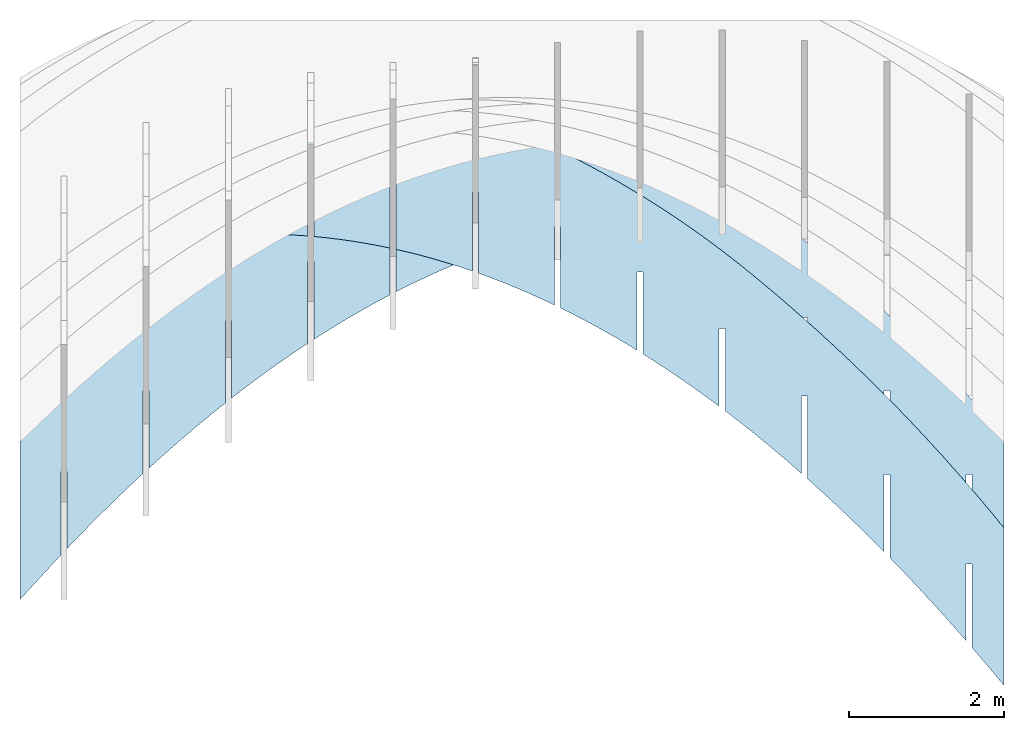
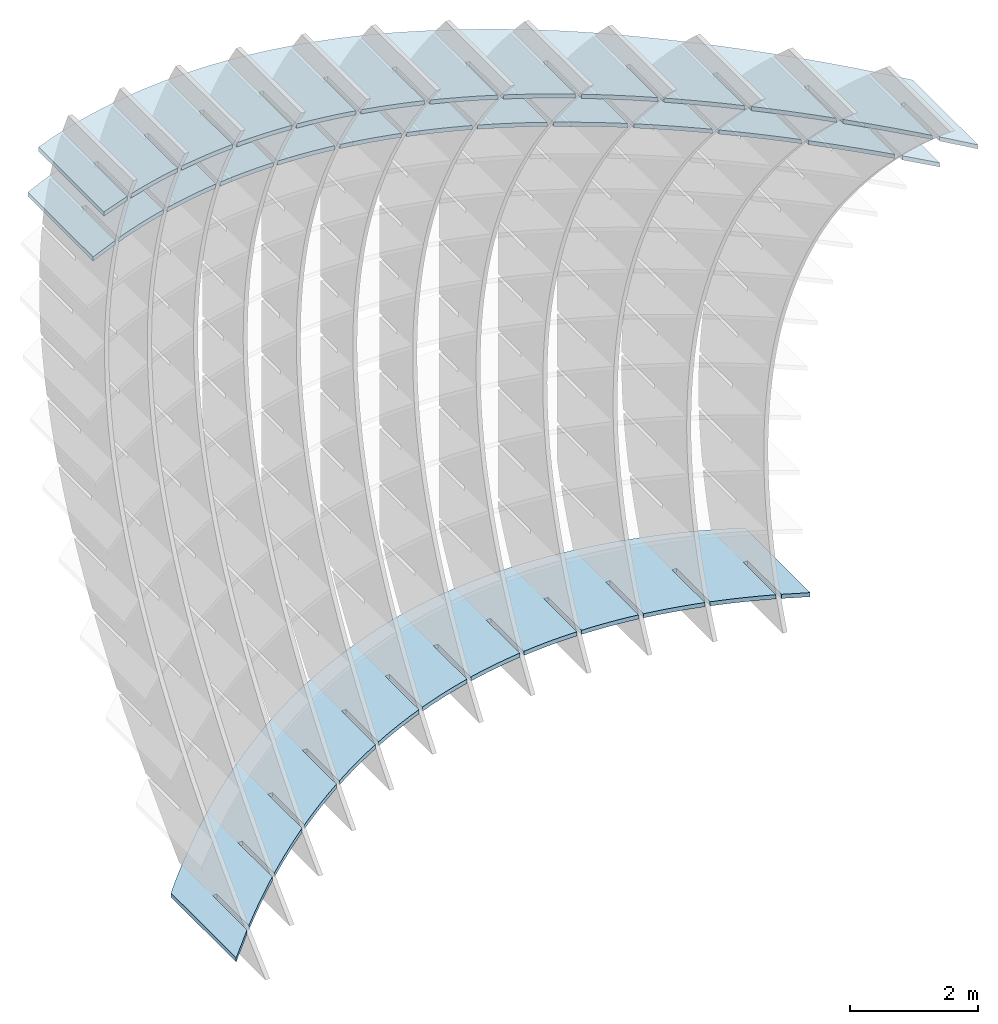
# Not in any storey, part 1 of 9: 3 slabs.
"""IFC2X3 building model written with IfcOpenShell, lengths in metres."""

from ifc_helpers import new_model, si_unit, point, direction, frame, frame_2d, origin_with_axes, place, context, project, spatial, polyline, circle_curve, parameter, trimmed, segment, composite_curve, outline, extrude, material, layer, layer_set, layer_usage, type_object, element, save


model = new_model("IFC2X3")

# Units and contexts
model_context = context("Model", 3, precision=2.54e-06, world=origin_with_axes(), true_north=direction((0.0, 1.0)), identifier="Body")
ifc_project = project(units=[si_unit("LENGTHUNIT", "METRE"), si_unit("AREAUNIT", "SQUARE_METRE"), si_unit("VOLUMEUNIT", "CUBIC_METRE"), si_unit("PLANEANGLEUNIT", "RADIAN")], contexts=[model_context])

# Building
building_placement = place(None, origin_with_axes())
building = spatial("IfcBuilding", under=ifc_project, at=building_placement, Name="Building", CompositionType="ELEMENT")

# Slabs
ifc_material = material(Name="MATERIAL")
ifc_layer = layer(ifc_material, 0.07874, ventilated=True)
ifc_layer_set = layer_set([ifc_layer], Name="SLAB")
ifc_layer_usage_1 = layer_usage(ifc_layer_set, "AXIS3", "NEGATIVE", -0.07874)
slab_type = type_object("IfcSlabType", Name="SLAB", PredefinedType="FLOOR", material=ifc_material)
slab_1_placement = place(None, frame((6.71456553163902, -0.741007703003649, 5.69856553163901), z_axis=(0.0, 0.0, 1.0), x_axis=(-0.94325399, -0.33207215, 0.0)))
element("IfcSlab", 1, at=slab_1_placement, inside=building, type_object=slab_type, material=ifc_layer_usage_1, PredefinedType="FLOOR", context=model_context, shape_type="SweptSolid", body=[
    extrude(outline(composite_curve([segment(polyline([(0.0, 0.0), (0.558668252688296, 0.0)]), True, "CONTINUOUS"), segment(polyline([(0.558668252688296, 0.0), (-0.11610235135044, -1.9166921067102)]), True, "CONTINUOUS"), segment(trimmed(circle_curve(frame_2d((-0.454176042762941, 6.49239333899888), x_axis=(-0.35335921, -0.93548772)), 8.41587855509225), [parameter(0.4013412910898), point((-0.11610235135044, -1.9166921067102))], [parameter(0.0), point((-3.42800425802684, -1.38055767063924))], False, "PARAMETER"), True, "CONTINUOUS"), segment(trimmed(circle_curve(frame_2d((-0.306689663633218, 6.61905905741665), x_axis=(-0.67241312, -0.74017606)), 8.58699438645248), [parameter(0.365449258808831), point((-3.42800425802684, -1.38055767063924))], [parameter(0.0), point((-6.08069736060079, 0.263171416156338))], False, "PARAMETER"), True, "CONTINUOUS"), segment(trimmed(circle_curve(frame_2d((2.48458686056573, 9.62720788152058), x_axis=(-0.85333858, -0.52135714)), 12.6905190088521), [parameter(0.281478210863516), point((-6.08069736060079, 0.263171416156338))], [parameter(0.0), point((-8.34472259524798, 3.01091515641694))], False, "PARAMETER"), True, "CONTINUOUS"), segment(trimmed(circle_curve(frame_2d((10.8123147849372, 14.7446452617049), x_axis=(-0.9424286, -0.33440745)), 22.4649171680991), [parameter(0.208585299590017), point((-8.34472259524798, 3.01091515641694))], [parameter(0.0), point((-10.3592655538927, 7.23220961632172))], False, "PARAMETER"), True, "CONTINUOUS"), segment(polyline([(-10.3592655538927, 7.23220961632172), (-9.68449494985437, 9.14890172303305)]), True, "CONTINUOUS"), segment(polyline([(-9.68449494985437, 9.14890172303305), (-9.45849064734703, 8.55531239844334)]), True, "CONTINUOUS"), segment(polyline([(-9.45849064734703, 8.55531239844334), (-9.81733794059514, 7.53600336161473)]), True, "CONTINUOUS"), segment(polyline([(-9.81733794059514, 7.53600336161473), (-9.74306612146012, 7.50985600070822)]), True, "CONTINUOUS"), segment(polyline([(-9.74306612146012, 7.50985600070822), (-9.4144259696499, 8.44336137446415)]), True, "CONTINUOUS"), segment(trimmed(circle_curve(frame_2d((14.1756864340152, 17.754117010977), x_axis=(-0.93017045, -0.36712796)), 25.3610641287075), [parameter(0.0), point((-9.4144259696499, 8.44336137446415))], [parameter(0.057323730803975), point((-8.84224291578231, 7.10712202703246))], True, "PARAMETER"), True, "CONTINUOUS"), segment(polyline([(-8.84224291578231, 7.10712202703246), (-9.19933753527756, 6.09279147612238)]), True, "CONTINUOUS"), segment(polyline([(-9.19933753527756, 6.09279147612238), (-9.12506571614254, 6.06664411521588)]), True, "CONTINUOUS"), segment(polyline([(-9.12506571614254, 6.06664411521588), (-8.79467293731748, 7.00512784212655)]), True, "CONTINUOUS"), segment(trimmed(circle_curve(frame_2d((10.1917840741912, 15.8938320340269), x_axis=(-0.9056641, -0.42399592)), 20.9641267898516), [parameter(0.0), point((-8.79467293731748, 7.00512784212655))], [parameter(0.0648548221772652), point((-8.1786857162643, 5.79331463446087))], True, "PARAMETER"), True, "CONTINUOUS"), segment(polyline([(-8.1786857162643, 5.79331463446087), (-8.53403083961089, 4.78395354344769)]), True, "CONTINUOUS"), segment(polyline([(-8.53403083961089, 4.78395354344769), (-8.45975902047587, 4.75780618254119)]), True, "CONTINUOUS"), segment(polyline([(-8.45975902047587, 4.75780618254119), (-8.12761674550289, 5.70125936935035)]), True, "CONTINUOUS"), segment(trimmed(circle_curve(frame_2d((6.88238227580404, 14.061089917788), x_axis=(-0.87363932, -0.48657409)), 17.1810022239166), [parameter(0.0), point((-8.12761674550289, 5.70125936935035))], [parameter(0.0740579088368179), point((-7.46792803416301, 4.61358064677484))], True, "PARAMETER"), True, "CONTINUOUS"), segment(polyline([(-7.46792803416301, 4.61358064677484), (-7.82152366136089, 3.60918901565891)]), True, "CONTINUOUS"), segment(polyline([(-7.82152366136089, 3.60918901565891), (-7.74725184222586, 3.58304165475241)]), True, "CONTINUOUS"), segment(polyline([(-7.74725184222586, 3.58304165475241), (-7.41336007110496, 4.53146430146006)]), True, "CONTINUOUS"), segment(trimmed(circle_curve(frame_2d((4.37460814870932, 12.3982060776481), x_axis=(-0.83178653, -0.55509564)), 14.1718672349332), [parameter(0.0), point((-7.41336007110496, 4.53146430146006))], [parameter(0.0842035553852759), point((-6.7099698694766, 3.56792006397204))], True, "PARAMETER"), True, "CONTINUOUS"), segment(polyline([(-6.7099698694766, 3.56792006397204), (-7.06181600052755, 2.56849789275605)]), True, "CONTINUOUS"), segment(polyline([(-7.06181600052755, 2.56849789275605), (-6.98754418139253, 2.54235053184955)]), True, "CONTINUOUS"), segment(polyline([(-6.98754418139253, 2.54235053184955), (-6.65190291412369, 3.49574263845568)]), True, "CONTINUOUS"), segment(trimmed(circle_curve(frame_2d((2.56081293727102, 10.9430782101666), x_axis=(-0.77768133, -0.62865869)), 11.8463893434333), [parameter(0.0), point((-6.65190291412369, 3.49574263845568))], [parameter(0.0948934985891319), point((-5.90481122220835, 2.65633288605717))], True, "PARAMETER"), True, "CONTINUOUS"), segment(polyline([(-5.90481122220835, 2.65633288605717), (-6.25490785711087, 1.66188017473909)]), True, "CONTINUOUS"), segment(polyline([(-6.25490785711087, 1.66188017473909), (-6.18063603797585, 1.63573281383259)]), True, "CONTINUOUS"), segment(polyline([(-6.18063603797585, 1.63573281383259), (-5.84324527455909, 2.59409438033722)]), True, "CONTINUOUS"), segment(trimmed(circle_curve(frame_2d((1.33334788585759, 9.73360401190503), x_axis=(-0.70893605, -0.70527277)), 10.1230473262447), [parameter(0.0), point((-5.84324527455909, 2.59409438033722))], [parameter(0.10538157879388), point((-5.05245209235639, 1.8788191130277))], True, "PARAMETER"), True, "CONTINUOUS"), segment(polyline([(-5.05245209235639, 1.8788191130277), (-5.40079923111085, 0.889335861608042)]), True, "CONTINUOUS"), segment(polyline([(-5.40079923111085, 0.889335861608042), (-5.32652741197583, 0.863188500701541)]), True, "CONTINUOUS"), segment(polyline([(-5.32652741197583, 0.863188500701541), (-4.98738715241115, 1.82651952710466)]), True, "CONTINUOUS"), segment(trimmed(circle_curve(frame_2d((0.584564238836988, 8.80768117942483), x_axis=(-0.6238087, -0.78157706)), 8.93214757615758), [parameter(0.0), point((-4.98738715241115, 1.82651952710466))], [parameter(0.114554431580325), point((-4.15289247992038, 1.23537874488364))], True, "PARAMETER"), True, "CONTINUOUS"), segment(polyline([(-4.15289247992038, 1.23537874488364), (-4.4994901225275, 0.250864953362905)]), True, "CONTINUOUS"), segment(polyline([(-4.4994901225275, 0.250864953362905), (-4.42521830339248, 0.224717592456404)]), True, "CONTINUOUS"), segment(polyline([(-4.42521830339248, 0.224717592456404), (-4.08432854767987, 1.19301807875801)]), True, "CONTINUOUS"), segment(trimmed(circle_curve(frame_2d((0.206813240577482, 8.20320740928781), x_axis=(-0.5220821, -0.85289523)), 8.2192853884509), [parameter(0.0), point((-4.08432854767987, 1.19301807875801))], [parameter(0.121087811880616), point((-3.20613238490233, 0.726011781626285))], True, "PARAMETER"), True, "CONTINUOUS"), segment(polyline([(-3.20613238490233, 0.726011781626285), (-3.5509805313608, -0.253532549996321)]), True, "CONTINUOUS"), segment(polyline([(-3.5509805313608, -0.253532549996321), (-3.47670871222578, -0.279679910902822)]), True, "CONTINUOUS"), segment(polyline([(-3.47670871222578, -0.279679910902822), (-3.13406946036525, 0.693590035297271)]), True, "CONTINUOUS"), segment(trimmed(circle_curve(frame_2d((0.0924461354468224, 7.95808039805507), x_axis=(-0.40591293, -0.91391176)), 7.94878752519021), [parameter(0.0), point((-3.13406946036525, 0.693590035297271))], [parameter(0.123820419877385), point((-2.21217180729974, 0.350718223254262))], True, "PARAMETER"), True, "CONTINUOUS"), segment(polyline([(-2.21217180729974, 0.350718223254262), (-2.55527045761078, -0.623856648469636)]), True, "CONTINUOUS"), segment(polyline([(-2.55527045761078, -0.623856648469636), (-2.48099863847576, -0.650004009376137)]), True, "CONTINUOUS"), segment(polyline([(-2.48099863847576, -0.650004009376137), (-2.1366098904673, 0.328235396722444)]), True, "CONTINUOUS"), segment(trimmed(circle_curve(frame_2d((0.13381416781312, 8.11019784228824), x_axis=(-0.28007788, -0.95997728)), 8.10640271073519), [parameter(0.0), point((-2.1366098904673, 0.328235396722444))], [parameter(0.12220968117817), point((-1.17101074711436, 0.109498069768374))], True, "PARAMETER"), True, "CONTINUOUS"), segment(polyline([(-1.17101074711436, 0.109498069768374), (-1.51235990127741, -0.860107342057041)]), True, "CONTINUOUS"), segment(polyline([(-1.51235990127741, -0.860107342057041), (-1.43808808214239, -0.886254702963542)]), True, "CONTINUOUS"), segment(polyline([(-1.43808808214239, -0.886254702963542), (-1.091949837986, 0.0969541630335281)]), True, "CONTINUOUS"), segment(trimmed(circle_curve(frame_2d((0.218834029128582, 8.66143180408086), x_axis=(-0.15128728, -0.98848984)), 8.66420403789566), [parameter(0.0), point((-1.091949837986, 0.0969541630335281))], [parameter(0.11707192567965), point((-0.0826063217169415, 0.00247312966916022))], True, "PARAMETER"), True, "CONTINUOUS"), segment(polyline([(-0.0826063217169415, 0.00247312966916022), (-0.422181667953309, -0.962093764426323)]), True, "CONTINUOUS"), segment(polyline([(-0.422181667953309, -0.962093764426323), (-0.347909848818288, -0.988241125332824)]), True, "CONTINUOUS"), segment(polyline([(-0.347909848818288, -0.988241125332824), (0.0, 0.0)]), True, "CONTINUOUS")], self_intersect="UNKNOWN")), origin_with_axes(), (0.0, 0.0, 1.0), 0.07874),
])
ifc_layer_usage_2 = layer_usage(ifc_layer_set, "AXIS3", "NEGATIVE", -0.07874)
slab_2_placement = place(None, frame((6.71456553163902, -0.369313085223885, 4.63638371345719), z_axis=(0.0, 0.0, 1.0), x_axis=(-0.92232465, -0.38641589, 0.0)))
element("IfcSlab", 2, at=slab_2_placement, inside=building, type_object=slab_type, material=ifc_layer_usage_2, PredefinedType="FLOOR", context=model_context, shape_type="SweptSolid", body=[
    extrude(outline(composite_curve([segment(polyline([(0.0, 0.0), (0.571345520836946, 0.0)]), True, "CONTINUOUS"), segment(polyline([(0.571345520836946, 0.0), (-0.213851562159434, -1.87416369105102)]), True, "CONTINUOUS"), segment(trimmed(circle_curve(frame_2d((-0.570675959928943, 6.87115965180384), x_axis=(-0.34316954, -0.93927348)), 8.75259984358508), [parameter(0.391068405592428), point((-0.213851562159434, -1.87416369105102))], [parameter(0.0), point((-3.57430162882539, -1.34992524394271))], False, "PARAMETER"), True, "CONTINUOUS"), segment(trimmed(circle_curve(frame_2d((-0.645289404038271, 6.40286119404841), x_axis=(-0.67091932, -0.74153035)), 8.28762994866756), [parameter(0.374223583295116), point((-3.57430162882539, -1.34992524394271))], [parameter(0.0), point((-6.20562048492513, 0.257332051901658))], False, "PARAMETER"), True, "CONTINUOUS"), segment(trimmed(circle_curve(frame_2d((1.65308828277165, 8.85796980066868), x_axis=(-0.86158512, -0.50761312)), 11.6503336081415), [parameter(0.298031940766068), point((-6.20562048492513, 0.257332051901658))], [parameter(0.0), point((-8.38466582121807, 2.94410763379093))], False, "PARAMETER"), True, "CONTINUOUS"), segment(trimmed(circle_curve(frame_2d((9.12504373635652, 13.273990087682), x_axis=(-0.95232563, -0.30508341)), 20.3296925776517), [parameter(0.22297224709584), point((-8.38466582121807, 2.94410763379093))], [parameter(0.0), point((-10.2354436296436, 7.07173813756134))], False, "PARAMETER"), True, "CONTINUOUS"), segment(polyline([(-10.2354436296436, 7.07173813756134), (-9.45024654664672, 8.94590182861081)]), True, "CONTINUOUS"), segment(polyline([(-9.45024654664672, 8.94590182861081), (-9.24857025888709, 8.36548332756579)]), True, "CONTINUOUS"), segment(polyline([(-9.24857025888709, 8.36548332756579), (-9.66512515410804, 7.37122076997518)]), True, "CONTINUOUS"), segment(polyline([(-9.66512515410804, 7.37122076997518), (-9.59250131107981, 7.34079438300907)]), True, "CONTINUOUS"), segment(polyline([(-9.59250131107981, 7.34079438300907), (-9.20906116617088, 8.25601632262367)]), True, "CONTINUOUS"), segment(trimmed(circle_curve(frame_2d((12.3640996567038, 16.0665670242962), x_axis=(-0.94027173, -0.34042485)), 22.9435387452113), [parameter(0.0), point((-9.20906116617088, 8.25601632262367))], [parameter(0.0612835566242296), point((-8.69020419209913, 6.94942604725222))], True, "PARAMETER"), True, "CONTINUOUS"), segment(polyline([(-8.69020419209913, 6.94942604725222), (-9.10471958780675, 5.96003151072291)]), True, "CONTINUOUS"), segment(polyline([(-9.10471958780675, 5.96003151072291), (-9.03209574477853, 5.9296051237568)]), True, "CONTINUOUS"), segment(polyline([(-9.03209574477853, 5.9296051237568), (-8.64661615474351, 6.84969495461548)]), True, "CONTINUOUS"), segment(trimmed(circle_curve(frame_2d((8.72382495673264, 14.4736519356208), x_axis=(-0.91568459, -0.40189767)), 18.9698957418189), [parameter(0.0), point((-8.64661615474351, 6.84969495461548))], [parameter(0.0693247809412866), point((-8.07678644402392, 5.66476999656354))], True, "PARAMETER"), True, "CONTINUOUS"), segment(polyline([(-8.07678644402392, 5.66476999656354), (-8.48926603783937, 4.68023465534824)]), True, "CONTINUOUS"), segment(polyline([(-8.48926603783937, 4.68023465534824), (-8.41664219481115, 4.64980826838213)]), True, "CONTINUOUS"), segment(polyline([(-8.41664219481115, 4.64980826838213), (-8.02912680288458, 5.57475729455615)]), True, "CONTINUOUS"), segment(trimmed(circle_curve(frame_2d((5.73158624291494, 12.8925990637479), x_axis=(-0.88291725, -0.46952863)), 15.5855071039657), [parameter(0.0), point((-8.02912680288458, 5.57475729455615))], [parameter(0.0790306201356097), point((-7.40844383553117, 4.51121247051071))], True, "PARAMETER"), True, "CONTINUOUS"), segment(polyline([(-7.40844383553117, 4.51121247051071), (-7.81888762745479, 3.53153632461038)]), True, "CONTINUOUS"), segment(polyline([(-7.81888762745479, 3.53153632461038), (-7.74626378442657, 3.50110993764428)]), True, "CONTINUOUS"), segment(polyline([(-7.74626378442657, 3.50110993764428), (-7.35671259060844, 4.43091815913364)]), True, "CONTINUOUS"), segment(trimmed(circle_curve(frame_2d((3.49687328030181, 11.4565035380083), x_axis=(-0.83947571, -0.54339721)), 12.9290052275138), [parameter(0.0), point((-7.35671259060844, 4.43091815913364))], [parameter(0.0895181356163967), point((-6.68517636662037, 3.48875346909348))], True, "PARAMETER"), True, "CONTINUOUS"), segment(polyline([(-6.68517636662037, 3.48875346909348), (-7.09358435665301, 2.51393651850936)]), True, "CONTINUOUS"), segment(polyline([(-7.09358435665301, 2.51393651850936), (-7.02096051362478, 2.48351013154325)]), True, "CONTINUOUS"), segment(polyline([(-7.02096051362478, 2.48351013154325), (-6.62937351791511, 3.41817754834796)]), True, "CONTINUOUS"), segment(trimmed(circle_curve(frame_2d((1.91442587166875, 10.2094650281551), x_axis=(-0.78282047, -0.62224762)), 10.9141235856499), [parameter(0.0), point((-6.62937351791511, 3.41817754834796))], [parameter(0.100224490194477), point((-5.90698403729308, 2.5973929923141))], True, "PARAMETER"), True, "CONTINUOUS"), segment(polyline([(-5.90698403729308, 2.5973929923141), (-6.31335622543403, 1.62743523704516)]), True, "CONTINUOUS"), segment(polyline([(-6.31335622543403, 1.62743523704516), (-6.2407323824058, 1.59700885007905)]), True, "CONTINUOUS"), segment(polyline([(-6.2407323824058, 1.59700885007905), (-5.84710958480458, 2.5365354621991)]), True, "CONTINUOUS"), segment(trimmed(circle_curve(frame_2d((0.878983819771463, 9.19558320392829), x_axis=(-0.71063974, -0.70355608)), 9.46484280449021), [parameter(0.0), point((-5.84710958480458, 2.5365354621991))], [parameter(0.110213642371293), point((-5.07386684754846, 1.83713104017139))], True, "PARAMETER"), True, "CONTINUOUS"), segment(polyline([(-5.07386684754846, 1.83713104017139), (-5.47820323379784, 0.872032480217778)]), True, "CONTINUOUS"), segment(polyline([(-5.47820323379784, 0.872032480217778), (-5.40557939076961, 0.841606093251668)]), True, "CONTINUOUS"), segment(polyline([(-5.40557939076961, 0.841606093251668), (-5.00992079127684, 1.78599190068707)]), True, "CONTINUOUS"), segment(trimmed(circle_curve(frame_2d((0.28528692737663, 8.45895773507499), x_axis=(-0.62160046, -0.78333445)), 8.51866760770696), [parameter(0.0), point((-5.00992079127684, 1.78599190068707))], [parameter(0.118233031779906), point((-4.18582479738661, 1.20796761266547))], True, "PARAMETER"), True, "CONTINUOUS"), segment(polyline([(-4.18582479738661, 1.20796761266547), (-4.58812538174445, 0.247728248027225)]), True, "CONTINUOUS"), segment(polyline([(-4.58812538174445, 0.247728248027225), (-4.51550153871622, 0.217301861061116)]), True, "CONTINUOUS"), segment(polyline([(-4.51550153871622, 0.217301861061116), (-4.1178071373319, 1.16654686381185)]), True, "CONTINUOUS"), segment(trimmed(circle_curve(frame_2d((0.0280749972495888, 8.04368829134245), x_axis=(-0.51628908, -0.85641437)), 8.03015646722401), [parameter(0.0), point((-4.1178071373319, 1.16654686381185))], [parameter(0.12298229343998), point((-3.24285788680742, 0.709902709796314))], True, "PARAMETER"), True, "CONTINUOUS"), segment(polyline([(-3.24285788680742, 0.709902709796314), (-3.64312266927386, -0.245477459526501)]), True, "CONTINUOUS"), segment(polyline([(-3.64312266927386, -0.245477459526501), (-3.57049882624564, -0.275903846492611)]), True, "CONTINUOUS"), segment(polyline([(-3.57049882624564, -0.275903846492611), (-3.17076862296976, 0.67820035157347)]), True, "CONTINUOUS"), segment(trimmed(circle_curve(frame_2d((0.00208783215389583, 7.99387454247557), x_axis=(-0.39789576, -0.91743063)), 7.97408972562079), [parameter(0.0), point((-3.17076862296976, 0.67820035157347))], [parameter(0.123558271913986), point((-2.24496611581119, 0.342936331564083))], True, "PARAMETER"), True, "CONTINUOUS"), segment(polyline([(-2.24496611581119, 0.342936331564083), (-2.64319509638607, -0.607584642443405)]), True, "CONTINUOUS"), segment(polyline([(-2.64319509638607, -0.607584642443405), (-2.57057125335785, -0.638011029409514)]), True, "CONTINUOUS"), segment(polyline([(-2.57057125335785, -0.638011029409514), (-2.16880524819042, 0.320952363971913)]), True, "CONTINUOUS"), segment(trimmed(circle_curve(frame_2d((0.10206523485406, 8.3536161582204), x_axis=(-0.27204241, -0.96228526)), 8.34748706990272), [parameter(0.0), point((-2.16880524819042, 0.320952363971913))], [parameter(0.119844445167165), point((-1.19214948439759, 0.107068477968648))], True, "PARAMETER"), True, "CONTINUOUS"), segment(polyline([(-1.19214948439759, 0.107068477968648), (-1.58834266308108, -0.838593300723482)]), True, "CONTINUOUS"), segment(polyline([(-1.58834266308108, -0.838593300723482), (-1.51571882005285, -0.869019687689592)]), True, "CONTINUOUS"), segment(polyline([(-1.51571882005285, -0.869019687689592), (-1.11191701299388, 0.0948029010071759)]), True, "CONTINUOUS"), segment(trimmed(circle_curve(frame_2d((0.218258335993376, 9.12906834216625), x_axis=(-0.14566623, -0.98933379)), 9.13166570349433), [parameter(0.0), point((-1.11191701299388, 0.0948029010071759))], [parameter(0.11304105051373), point((-0.0843580921790454, 0.00241825476974128))], True, "PARAMETER"), True, "CONTINUOUS"), segment(polyline([(-0.0843580921790454, 0.00241825476974128), (-0.478487178559872, -0.938316803061464)]), True, "CONTINUOUS"), segment(polyline([(-0.478487178559872, -0.938316803061464), (-0.405863335531644, -0.968743190027574)]), True, "CONTINUOUS"), segment(polyline([(-0.405863335531644, -0.968743190027574), (0.0, 0.0)]), True, "CONTINUOUS")], self_intersect="UNKNOWN")), origin_with_axes(), (0.0, 0.0, 1.0), 0.07874),
])
ifc_layer_usage_3 = layer_usage(ifc_layer_set, "AXIS3", "NEGATIVE", -0.07874)
slab_3_placement = place(None, frame((6.71456553163902, -4.47341372654168, -5.98543446836099), z_axis=(0.0, 0.0, 1.0), x_axis=(-0.67668791, -0.73626998, 0.0)))
element("IfcSlab", 3, at=slab_3_placement, inside=building, type_object=slab_type, material=ifc_layer_usage_3, PredefinedType="FLOOR", context=model_context, shape_type="SweptSolid", body=[
    extrude(outline(composite_curve([segment(polyline([(0.0, 0.0), (0.778743129784174, 0.0)]), True, "CONTINUOUS"), segment(polyline([(0.778743129784174, 0.0), (-0.717357461012448, -1.3750298259376)]), True, "CONTINUOUS"), segment(trimmed(circle_curve(frame_2d((-1.14772490329394, 21.5574681936484), x_axis=(-0.09142659, -0.99581182)), 22.9365359536634), [parameter(0.110318939486038), point((-0.717357461012448, -1.3750298259376))], [parameter(0.0), point((-3.24473406165838, -1.28300540353052))], False, "PARAMETER"), True, "CONTINUOUS"), segment(trimmed(circle_curve(frame_2d((-1.70529731870461, 15.4277332078879), x_axis=(-0.20696739, -0.97834784)), 16.7814972640914), [parameter(0.116610896290393), point((-3.24473406165838, -1.28300540353052))], [parameter(0.0), point((-5.17852008467663, -0.990408405663866))], False, "PARAMETER"), True, "CONTINUOUS"), segment(trimmed(circle_curve(frame_2d((-2.92793432290146, 10.1469296479959), x_axis=(-0.4815721, -0.87640648)), 11.3624572691211), [parameter(0.303056968094598), point((-5.17852008467663, -0.990408405663866))], [parameter(0.0), point((-8.39977667548163, 0.188798474873445))], False, "PARAMETER"), True, "CONTINUOUS"), segment(trimmed(circle_curve(frame_2d((-4.4035557177296, 7.36991134472072), x_axis=(-0.77337544, -0.63394828)), 8.21816062100655), [parameter(0.376335826421611), point((-8.39977667548163, 0.188798474873445))], [parameter(0.0), point((-10.759279325989, 2.16002253515129))], False, "PARAMETER"), True, "CONTINUOUS"), segment(trimmed(circle_curve(frame_2d((-3.83238206232703, 7.7134800666587), x_axis=(-0.95870082, -0.28441647)), 8.87822033155205), [parameter(0.387393373093519), point((-10.759279325989, 2.16002253515129))], [parameter(0.0), point((-12.3439392137479, 5.18836796742821))], False, "PARAMETER"), True, "CONTINUOUS"), segment(polyline([(-12.3439392137479, 5.18836796742821), (-10.8478386229511, 6.56339779336528)]), True, "CONTINUOUS"), segment(polyline([(-10.8478386229511, 6.56339779336528), (-10.7048463029495, 6.1375583886891)]), True, "CONTINUOUS"), segment(polyline([(-10.7048463029495, 6.1375583886891), (-11.4791477056696, 5.42591671863366)]), True, "CONTINUOUS"), segment(polyline([(-11.4791477056696, 5.42591671863366), (-11.4258652999145, 5.36794282074029)]), True, "CONTINUOUS"), segment(polyline([(-11.4258652999145, 5.36794282074029), (-10.6758703468645, 6.05724502146819)]), True, "CONTINUOUS"), segment(trimmed(circle_curve(frame_2d((-1.86927682161733, 9.25944155464804), x_axis=(-0.93980032, -0.34172411)), 9.37070713212375), [parameter(0.0), point((-10.6758703468645, 6.05724502146819))], [parameter(0.111332939286559), point((-10.2655738159414, 5.09863046314932))], True, "PARAMETER"), True, "CONTINUOUS"), segment(polyline([(-10.2655738159414, 5.09863046314932), (-11.0359891924732, 4.39056034566578)]), True, "CONTINUOUS"), segment(polyline([(-11.0359891924732, 4.39056034566578), (-10.9827067867182, 4.33258644777242)]), True, "CONTINUOUS"), segment(polyline([(-10.9827067867182, 4.33258644777242), (-10.2288259111092, 5.02546010582926)]), True, "CONTINUOUS"), segment(trimmed(circle_curve(frame_2d((-2.63081840917119, 8.8774699463014), x_axis=(-0.8919244, -0.45218455)), 8.51866760770724), [parameter(0.0), point((-10.2288259111092, 5.02546010582926))], [parameter(0.118233031779901), point((-9.7214068321463, 4.15610852965768))], True, "PARAMETER"), True, "CONTINUOUS"), segment(polyline([(-9.7214068321463, 4.15610852965768), (-10.4879432278733, 3.45160348950427)]), True, "CONTINUOUS"), segment(polyline([(-10.4879432278733, 3.45160348950427), (-10.4346608221182, 3.3936295916109)]), True, "CONTINUOUS"), segment(polyline([(-10.4346608221182, 3.3936295916109), (-9.67690096570477, 4.09006832699826)]), True, "CONTINUOUS"), segment(trimmed(circle_curve(frame_2d((-3.03794476056751, 8.60755362242175), x_axis=(-0.82675303, -0.56256504)), 8.03015646722391), [parameter(0.0), point((-9.67690096570477, 4.09006832699826))], [parameter(0.122982293439982), point((-9.07258699380078, 3.30977050068344))], True, "PARAMETER"), True, "CONTINUOUS"), segment(polyline([(-9.07258699380078, 3.30977050068344), (-9.83524440872375, 2.60883053786123)]), True, "CONTINUOUS"), segment(polyline([(-9.83524440872375, 2.60883053786123), (-9.78196200296867, 2.55085663996786)]), True, "CONTINUOUS"), segment(polyline([(-9.78196200296867, 2.55085663996786), (-9.02032316575071, 3.25086045268575)]), True, "CONTINUOUS"), segment(trimmed(circle_curve(frame_2d((-3.08235961116596, 8.57314340050764), x_axis=(-0.74465723, -0.66744709)), 7.97408972562088), [parameter(0.0), point((-9.02032316575071, 3.25086045268575))], [parameter(0.123558271913985), point((-8.31911430090614, 2.5596163762284))], True, "PARAMETER"), True, "CONTINUOUS"), segment(polyline([(-8.31911430090614, 2.5596163762284), (-9.07789273502459, 1.86224149073666)]), True, "CONTINUOUS"), segment(polyline([(-9.07789273502459, 1.86224149073666), (-9.02461032926951, 1.80426759284329)]), True, "CONTINUOUS"), segment(polyline([(-9.02461032926951, 1.80426759284329), (-8.25909251124705, 2.5078364828917)]), True, "CONTINUOUS"), segment(trimmed(circle_curve(frame_2d((-2.84128989230413, 8.85826600886597), x_axis=(-0.64903396, -0.76075943)), 8.34748706990256), [parameter(0.0), point((-8.25909251124705, 2.5078364828917))], [parameter(0.119844445167166), point((-7.46098875346223, 1.90564615629204))], True, "PARAMETER"), True, "CONTINUOUS"), segment(polyline([(-7.46098875346223, 1.90564615629204), (-8.21588820677582, 1.21183634813058)]), True, "CONTINUOUS"), segment(polyline([(-8.21588820677582, 1.21183634813058), (-8.16260580102074, 1.15386245023721)]), True, "CONTINUOUS"), segment(polyline([(-8.16260580102074, 1.15386245023721), (-7.39320900219378, 1.86099641761614)]), True, "CONTINUOUS"), segment(trimmed(circle_curve(frame_2d((-2.39196253531819, 9.54694817580525), x_axis=(-0.54540056, -0.83817553)), 9.1698593583351), [parameter(0.0), point((-7.39320900219378, 1.86099641761614))], [parameter(0.112565458213441), point((-6.49821035146756, 1.34785984087347))], True, "PARAMETER"), True, "CONTINUOUS"), segment(polyline([(-6.49821035146756, 1.34785984087347), (-7.24923082397744, 0.65761511004297)]), True, "CONTINUOUS"), segment(polyline([(-7.24923082397744, 0.65761511004297), (-7.19594841822236, 0.599641212149601)]), True, "CONTINUOUS"), segment(polyline([(-7.19594841822236, 0.599641212149601), (-6.4226726385909, 1.31034025685905)]), True, "CONTINUOUS"), segment(trimmed(circle_curve(frame_2d((-1.81160447154585, 10.7232166296321), x_axis=(-0.43991975, -0.89803709)), 10.4816120539851), [parameter(0.0), point((-6.4226726385909, 1.31034025685905))], [parameter(0.102963694064146), point((-5.43077909492541, 0.886257429974375))], True, "PARAMETER"), True, "CONTINUOUS"), segment(polyline([(-5.43077909492541, 0.886257429974375), (-6.17792058662946, 0.19957777647384)]), True, "CONTINUOUS"), segment(polyline([(-6.17792058662946, 0.19957777647384), (-6.12463818087437, 0.141603878580471)]), True, "CONTINUOUS"), segment(polyline([(-6.12463818087437, 0.141603878580471), (-5.34748342043841, 0.855868000620448)]), True, "CONTINUOUS"), segment(trimmed(circle_curve(frame_2d((-1.17744263232446, 12.4710980986525), x_axis=(-0.33789856, -0.94118253)), 12.3411024793072), [parameter(0.0), point((-5.34748342043841, 0.855868000620448))], [parameter(0.092339664513003), point((-4.25869498383107, 0.520838923592793))], True, "PARAMETER"), True, "CONTINUOUS"), segment(polyline([(-4.25869498383107, 0.520838923592793), (-5.00195749473186, -0.16227565257681)]), True, "CONTINUOUS"), segment(polyline([(-5.00195749473186, -0.16227565257681), (-4.94867508897678, -0.220249550470179)]), True, "CONTINUOUS"), segment(polyline([(-4.94867508897678, -0.220249550470179), (-4.16764134773632, 0.497579648900319)]), True, "CONTINUOUS"), segment(trimmed(circle_curve(frame_2d((-0.566703948989754, 14.8746193111777), x_axis=(-0.24295964, -0.9700364)), 14.8211342211178), [parameter(0.0), point((-4.16764134773632, 0.497579648900319))], [parameter(0.0817255920081519), point((-2.98195801818978, 0.251604321730373))], True, "PARAMETER"), True, "CONTINUOUS"), segment(polyline([(-2.98195801818978, 0.251604321730373), (-3.72134154828466, -0.427945177108981)]), True, "CONTINUOUS"), segment(polyline([(-3.72134154828466, -0.427945177108981), (-3.66805914252958, -0.48591907500235)]), True, "CONTINUOUS"), segment(polyline([(-3.66805914252958, -0.48591907500235), (-2.88314642048461, 0.23547520169867)]), True, "CONTINUOUS"), segment(trimmed(circle_curve(frame_2d((-0.0566153528795232, 18.0178069955139), x_axis=(-0.15698091, -0.98760164)), 18.0055714128008), [parameter(0.0), point((-2.88314642048461, 0.23547520169867))], [parameter(0.0717788694798306), point((-1.6005681979967, 0.0785536243860107))], True, "PARAMETER"), True, "CONTINUOUS"), segment(polyline([(-1.6005681979967, 0.0785536243860107), (-2.33607274728785, -0.597430797122674)]), True, "CONTINUOUS"), segment(polyline([(-2.33607274728785, -0.597430797122674), (-2.28279034153277, -0.655404695016044)]), True, "CONTINUOUS"), segment(polyline([(-2.28279034153277, -0.655404695016044), (-1.4939986386833, 0.0695546590154986)]), True, "CONTINUOUS"), segment(trimmed(circle_curve(frame_2d((0.269704614980569, 21.893661525982), x_axis=(-0.08055184, -0.99675042)), 21.895257242329), [parameter(0.0), point((-1.4939986386833, 0.0695546590154986))], [parameter(0.0630940933256412), point((-0.114430443938838, 0.00177421665510846))], True, "PARAMETER"), True, "CONTINUOUS"), segment(polyline([(-0.114430443938838, 0.00177421665510846), (-0.846002108380262, -0.67059558561817)]), True, "CONTINUOUS"), segment(polyline([(-0.846002108380262, -0.67059558561817), (-0.79271970262518, -0.72856948351154)]), True, "CONTINUOUS"), segment(polyline([(-0.79271970262518, -0.72856948351154), (0.0, 0.0)]), True, "CONTINUOUS")], self_intersect="UNKNOWN")), origin_with_axes(), (0.0, 0.0, 1.0), 0.07874),
])

save(model, "model.ifc")
